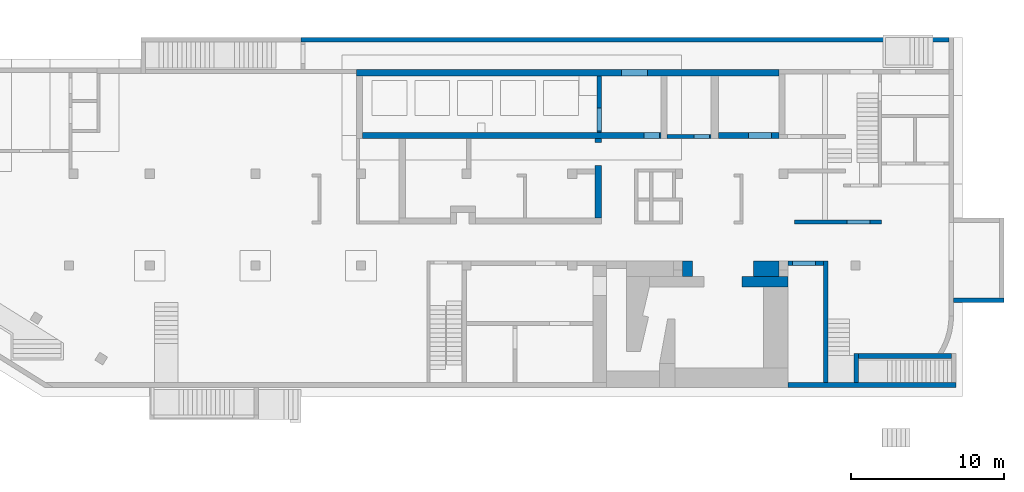
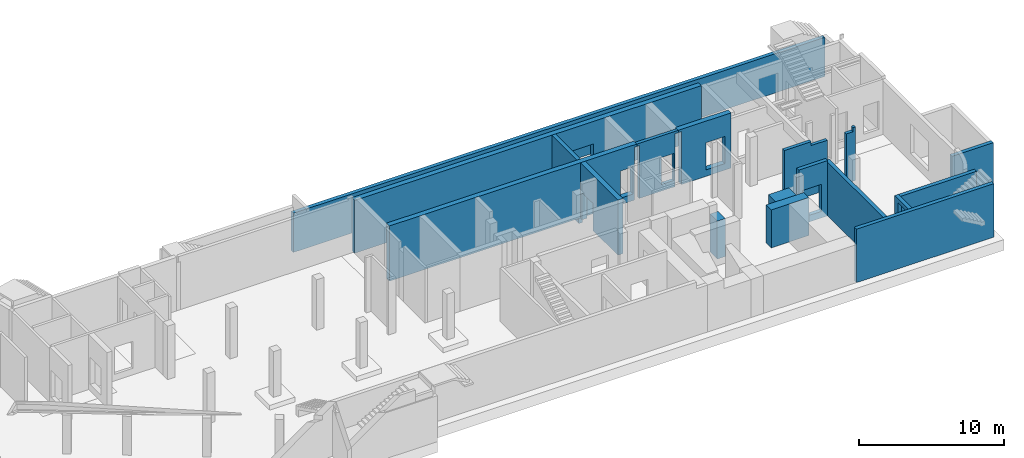
# One storey, part 7 of 9: 17 walls, 8 openings.
"""IFC4 building model written with IfcOpenShell, lengths in millimetres."""

from ifc_helpers import new_model, entity, si_unit, converted_unit, derived_unit, direction, frame, origin, place, context, subcontext, project, spatial, indexed_curve, outline, extrude, triangles, polygons, material, type_object, element, save


model = new_model("IFC4")

# Units and contexts
model_context = context("Model", 3, precision=0.01, world=origin(), true_north=direction((6.12303176911189e-17, 1.0)))
plan_context = context("Plan", 3, precision=0.01, world=origin(), true_north=direction((6.12303176911189e-17, 1.0)))
body_context = subcontext(model_context, "Body", "Model", "MODEL_VIEW")
ifc_project = project(units=[si_unit("LENGTHUNIT", "METRE", prefix="MILLI"), si_unit("AREAUNIT", "SQUARE_METRE"), si_unit("VOLUMEUNIT", "CUBIC_METRE"), converted_unit("PLANEANGLEUNIT", "DEGREE", entity("IfcRatioMeasure", 0.0174532925199433), si_unit("PLANEANGLEUNIT", "RADIAN"), dimensions=[0, 0, 0, 0, 0, 0, 0]), si_unit("MASSUNIT", "GRAM", prefix="KILO"), derived_unit("MASSDENSITYUNIT", [(si_unit("MASSUNIT", "GRAM", prefix="KILO"), 1), (si_unit("LENGTHUNIT", "METRE"), -3)]), derived_unit("MOMENTOFINERTIAUNIT", [(si_unit("LENGTHUNIT", "METRE"), 4)]), si_unit("TIMEUNIT", "SECOND"), si_unit("FREQUENCYUNIT", "HERTZ"), si_unit("THERMODYNAMICTEMPERATUREUNIT", "DEGREE_CELSIUS"), derived_unit("THERMALTRANSMITTANCEUNIT", [(si_unit("MASSUNIT", "GRAM", prefix="KILO"), 1), (si_unit("THERMODYNAMICTEMPERATUREUNIT", "KELVIN"), -1), (si_unit("TIMEUNIT", "SECOND"), -3)]), derived_unit("VOLUMETRICFLOWRATEUNIT", [(si_unit("LENGTHUNIT", "METRE"), 3), (si_unit("TIMEUNIT", "SECOND"), -1)]), derived_unit("MASSFLOWRATEUNIT", [(si_unit("MASSUNIT", "GRAM", prefix="KILO"), 1), (si_unit("TIMEUNIT", "SECOND"), -1)]), derived_unit("ROTATIONALFREQUENCYUNIT", [(si_unit("TIMEUNIT", "SECOND"), -1)]), si_unit("ELECTRICCURRENTUNIT", "AMPERE"), si_unit("ELECTRICVOLTAGEUNIT", "VOLT"), si_unit("POWERUNIT", "WATT"), si_unit("FORCEUNIT", "NEWTON", prefix="KILO"), si_unit("ILLUMINANCEUNIT", "LUX"), si_unit("LUMINOUSFLUXUNIT", "LUMEN"), si_unit("LUMINOUSINTENSITYUNIT", "CANDELA"), derived_unit("USERDEFINED", [(si_unit("MASSUNIT", "GRAM", prefix="KILO"), -1), (si_unit("LENGTHUNIT", "METRE"), -2), (si_unit("TIMEUNIT", "SECOND"), 3), (si_unit("LUMINOUSFLUXUNIT", "LUMEN"), 1)]), derived_unit("LINEARVELOCITYUNIT", [(si_unit("LENGTHUNIT", "METRE"), 1), (si_unit("TIMEUNIT", "SECOND"), -1)]), si_unit("PRESSUREUNIT", "PASCAL"), derived_unit("USERDEFINED", [(si_unit("LENGTHUNIT", "METRE"), -2), (si_unit("MASSUNIT", "GRAM", prefix="KILO"), 1), (si_unit("TIMEUNIT", "SECOND"), -2)]), derived_unit("LINEARFORCEUNIT", [(si_unit("MASSUNIT", "GRAM", prefix="KILO"), 1), (si_unit("LENGTHUNIT", "METRE"), 1), (si_unit("TIMEUNIT", "SECOND"), -2), (si_unit("LENGTHUNIT", "METRE"), -1)]), derived_unit("PLANARFORCEUNIT", [(si_unit("MASSUNIT", "GRAM", prefix="KILO"), 1), (si_unit("LENGTHUNIT", "METRE"), 1), (si_unit("TIMEUNIT", "SECOND"), -2), (si_unit("LENGTHUNIT", "METRE"), -2)])], contexts=[model_context, plan_context])

# Site, building, storey
site_placement = place(None, origin())
site = spatial("IfcSite", under=ifc_project, at=site_placement, CompositionType="ELEMENT")
building_placement = place(site_placement, origin())
building = spatial("IfcBuilding", under=site, at=building_placement, CompositionType="ELEMENT")
storey_placement = place(building_placement, frame((0.0, 0.0, -4900.0)))
storey = spatial("IfcBuildingStorey", under=building, at=storey_placement, CompositionType="ELEMENT", Elevation=-4900.0)

# Walls
ifc_material = material()
wall_type_1 = type_object("IfcWallType", PredefinedType="STANDARD")
wall_1_placement = place(storey_placement, frame((62870.0002685546, -100.000773643981, 0.0)))
element("IfcWall", 1, at=wall_1_placement, inside=storey, type_object=wall_type_1, material=ifc_material, PredefinedType="NOTDEFINED", context=body_context, shape_type="Tessellation", body=[
    polygons([(1.69593855051474e-12, -150.0, 0.0), (10955.0, -150.0, 0.0), (10955.0, -150.0, 4500.0), (4600.0, -150.0, 4500.0), (1.69593855051474e-12, -150.0, 4500.0), (1.69593855051474e-12, -150.0, 3200.0), (-3.39181412269712e-13, 150.0, 0.0), (-3.39181412269712e-13, 150.0, 4500.0), (2300.0, 150.0, 4500.0), (2600.0, 150.0, 4500.0), (4299.99999999999, 150.0, 4500.0), (4600.00000000002, 150.000000000001, 4500.0), (10955.0, 150.0, 4500.0), (10955.0, 150.0, 4229.99999999996), (10955.0, 150.0, 0.0), (10655.0, 150.0, 0.0), (4599.99999999999, 150.0, 0.0), (4299.99999999999, 150.0, 0.0), (2600.0, 150.0, 0.0), (2300.0, 150.0, 0.0)], [[[1, 2, 3, 4, 5, 6]], [[7, 8, 9, 10, 11, 12, 13, 14, 15, 16, 17, 18, 19, 20]], [[2, 1, 7, 20, 19, 18, 17, 16, 15]], [[1, 6, 5, 8, 7]], [[3, 2, 15, 14, 13]], [[4, 3, 13, 12]], [[5, 4, 12, 11, 10, 9, 8]]], closed=True),
])
wall_2_placement = place(storey_placement, frame((65320.0002685546, 49.9992263560015, 0.0), z_axis=(0.0, 0.0, 1.0), x_axis=(0.0, 1.0, 0.0)))
element("IfcWall", 2, at=wall_2_placement, inside=storey, type_object=wall_type_1, material=ifc_material, PredefinedType="NOTDEFINED", context=body_context, shape_type="Tessellation", body=[
    polygons([(1.01518793371724e-13, -150.000000000001, 0.0), (7950.00000000001, -150.000000000001, 0.0), (7950.00000000001, -150.000000000001, 4500.0), (3.38395977905748e-14, -150.000000000001, 4500.0), (2.16573425859679e-12, 150.000000000001, 0.0), (2.14035456025385e-12, 150.000000000001, 4500.0), (7950.00000000001, 150.000000000001, 4500.0), (7950.00000000001, 150.000000000001, 0.0), (7650.00000000001, 150.000000000001, 0.0)], [[[1, 2, 3, 4]], [[5, 6, 7, 8, 9]], [[2, 1, 5, 9, 8]], [[3, 2, 8, 7]], [[1, 4, 6, 5]], [[4, 3, 7, 6]]], closed=True),
])

# Wall, opening
wall_3_placement = place(storey_placement, frame((62870.0002685546, 7849.99922635602, 0.0)))
wall_3 = element("IfcWall", 3, at=wall_3_placement, inside=storey, type_object=wall_type_1, material=ifc_material, PredefinedType="NOTDEFINED", context=body_context, shape_type="Tessellation", body=[
    polygons([(2.00999830337293e-12, -149.999999999999, 0.0), (2299.99999999999, -149.999999999998, 0.0), (2299.99999999999, -149.999999999998, 4650.0), (2.00999830337293e-12, -149.999999999999, 4650.0), (299.999999999986, -149.999999999997, 2829.99999999805), (1799.99999999999, -149.999999999998, 2829.99999999804), (1799.99999999999, -149.999999999998, 550.0), (299.999999999986, -149.999999999997, 550.0), (2299.99999999999, 150.000000000002, 0.0), (4.00724627324388e-13, 150.000000000002, 0.0), (4.00724627324396e-13, 150.000000000001, 3200.0), (4.00724627324388e-13, 150.000000000002, 4650.0), (2299.99999999999, 150.000000000002, 4650.0), (2299.99999999999, 150.000000000002, 4500.0), (1799.99999999999, 150.000000000001, 2829.99999999804), (299.999999999993, 150.000000000002, 2829.99999999805), (299.999999999984, 150.000000000002, 550.0), (1799.99999999999, 150.000000000001, 550.0)], [[[1, 2, 3, 4], [5, 6, 7, 8]], [[9, 10, 11, 12, 13, 14], [15, 16, 17, 18]], [[2, 1, 10, 9]], [[4, 3, 13, 12]], [[1, 4, 12, 11, 10]], [[3, 2, 9, 14, 13]], [[5, 16, 15, 6]], [[6, 15, 18, 7]], [[7, 18, 17, 8]], [[16, 5, 8, 17]]], closed=True),
])
opening_1_placement = place(wall_3_placement, frame((-62870.0002685546, -7849.99922635602, 0.0)))
element("IfcOpeningElement", 4, at=opening_1_placement, cuts=wall_3, PredefinedType="OPENING", context=body_context, shape_type="SweptSolid", body=[
    extrude(outline(indexed_curve([(-750.000000000003, -1139.99999999902), (749.999999999994, -1139.99999999902), (749.999999999994, 1139.99999999902), (-750.000000000003, 1139.99999999902), (-750.000000000003, -1139.99999999902)], self_intersect=False)), frame((63920.0002685546, 7599.99922635407, 1690.0), z_axis=(0.0, 1.0, 0.0), x_axis=(1.0, 0.0, 0.0)), (0.0, 0.0, 1.0), 500.000000001943),
])

# Wall
wall_4_placement = place(storey_placement, frame((73525.0002685546, 1794.99922635597, 0.0), z_axis=(0.0, 0.0, 1.0), x_axis=(-1.0, 0.0, 0.0)))
element("IfcWall", 5, at=wall_4_placement, inside=storey, type_object=wall_type_1, material=ifc_material, PredefinedType="NOTDEFINED", context=body_context, shape_type="Tessellation", body=[
    triangles([(547.133825683544, -149.999930977401, 4499.99999694824), (-0.000219726614886895, -149.999930977401, 4229.99998035431), (903.567883300726, -149.999930977401, 0.000253295897891803), (-0.000219726614886895, -149.999930977401, 4499.99999694824), (-0.000219726614886895, -149.999930977401, 0.000253295897891803), (547.138476562439, -149.999930977401, 0.000253295897891803), (6055.00228271479, -149.999930977401, 4499.99999694824), (6055.00228271479, -149.999930977401, 0.000253295897891803), (6055.00228271479, 150.000071311417, 4499.99999694824), (6055.00228271479, 150.000071311417, 0.000253295897891803), (747.116967773385, 150.000071311417, 4499.99999694824), (-0.000219726614886895, 150.000071311417, 0.000253295897891803), (-0.000219726614886895, 150.000071311417, 4499.99999694824), (644.248828124939, 1.91826703590436, 4499.99999694824)], [[1, 2, 3], [1, 4, 2], [2, 5, 6], [7, 1, 3], [7, 3, 8], [3, 2, 6], [9, 10, 11], [11, 12, 13], [12, 11, 10], [6, 5, 12], [3, 12, 10], [12, 3, 6], [3, 10, 8], [13, 12, 2], [5, 2, 12], [4, 13, 2], [8, 10, 9], [9, 7, 8], [4, 1, 13], [14, 11, 13], [14, 13, 1], [7, 11, 14], [1, 7, 14], [9, 11, 7]]),
])

# Wall, opening
wall_5_placement = place(storey_placement, frame((67320.0002685546, 1944.99922635597, 0.0), z_axis=(0.0, 0.0, 1.0), x_axis=(0.0, -1.0, 0.0)))
wall_5 = element("IfcWall", 6, at=wall_5_placement, inside=storey, type_object=wall_type_1, material=ifc_material, PredefinedType="NOTDEFINED", context=body_context, shape_type="Tessellation", body=[
    polygons([(0.0, -150.000000000001, 0.0), (1894.99999999998, -150.000000000001, 0.0), (1894.99999999998, -150.000000000001, 4500.0), (0.0, -150.000000000001, 4500.0), (472.499999999996, -150.000000000001, 4179.99999999804), (1722.5, -150.000000000001, 4179.99999999804), (1722.5, -150.000000000001, 1825.0), (472.499999999996, -150.000000000001, 1825.0), (1894.99999999998, 150.000000000001, 0.0), (300.0, 150.000000000001, 0.0), (0.0, 150.000000000001, 0.0), (0.0, 150.000000000001, 4500.0), (299.999999999991, 150.000000000001, 4500.0), (1894.99999999998, 150.000000000001, 4500.0), (1722.5, 150.000000000001, 4179.99999999804), (472.499999999996, 150.000000000001, 4179.99999999804), (472.499999999996, 150.000000000001, 1825.0), (1722.5, 150.000000000001, 1825.0)], [[[1, 2, 3, 4], [5, 6, 7, 8]], [[9, 10, 11, 12, 13, 14], [15, 16, 17, 18]], [[2, 1, 11, 10, 9]], [[3, 2, 9, 14]], [[1, 4, 12, 11]], [[12, 4, 3, 14, 13]], [[5, 16, 15, 6]], [[6, 15, 18, 7]], [[7, 18, 17, 8]], [[16, 5, 8, 17]]], closed=True),
])
opening_2_placement = place(wall_5_placement, frame((1944.99922635597, -67320.0002685546, 0.0), z_axis=(0.0, 0.0, 1.0), x_axis=(0.0, 1.0, 0.0)))
element("IfcOpeningElement", 7, at=opening_2_placement, cuts=wall_5, PredefinedType="OPENING", context=body_context, shape_type="SweptSolid", body=[
    extrude(outline(indexed_curve([(-625.0, -1177.49999999902), (625.0, -1177.49999999902), (625.0, 1177.49999999902), (-625.0, 1177.49999999902), (-625.0, -1177.49999999902)], self_intersect=False)), frame((67070.0002685527, 847.499226355978, 3002.49999999902), z_axis=(1.0, 0.0, 0.0), x_axis=(0.0, -1.0, 0.0)), (0.0, 0.0, 1.0), 500.000000001948),
])

# Walls
wall_6_placement = place(storey_placement, frame((73670.0002685546, 5424.99922635595, 0.0)))
element("IfcWall", 8, at=wall_6_placement, inside=storey, type_object=wall_type_1, material=ifc_material, PredefinedType="NOTDEFINED", context=body_context, shape_type="Tessellation", body=[
    polygons([(4.01064381973369e-13, -149.999999999999, 0.0), (600.000000000003, -149.999999999999, 0.0), (3300.0, -149.999999999999, 0.0), (3300.0, -149.999999999999, 3500.0), (4.01064381973369e-13, -149.999999999999, 3500.0), (8.10145285698416e-12, 150.000000000001, 0.0), (8.10145285698416e-12, 150.000000000001, 3500.0), (3000.0, 150.000000000001, 3500.0), (3300.00000000002, 150.000000000001, 3500.0), (3299.99999999999, 150.000000000001, 0.0), (3000.0, 150.000000000001, 0.0)], [[[1, 2, 3, 4, 5]], [[6, 7, 8, 9, 10, 11]], [[3, 2, 1, 6, 11, 10]], [[4, 3, 10, 9]], [[1, 5, 7, 6]], [[5, 4, 9, 8, 7]]], closed=True),
])
wall_7_placement = place(storey_placement, frame((73370.0002685547, 22449.9992263559, 0.0), z_axis=(0.0, 0.0, 1.0), x_axis=(-1.0, 0.0, 0.0)))
element("IfcWall", 9, at=wall_7_placement, inside=storey, type_object=wall_type_1, material=ifc_material, PredefinedType="NOTDEFINED", context=body_context, shape_type="Tessellation", body=[
    polygons([(5.41415833087696e-13, -150.000000000001, 0.0), (42310.0, -149.999999999996, 0.0), (42310.0, -149.999999999996, 3300.0), (5.41415833087696e-13, -150.000000000001, 3300.0), (-2.70734306312946e-13, 150.000000000001, 0.0), (-2.70734306312946e-13, 150.000000000001, 3300.0), (42060.0, 150.000000000001, 3300.0), (42310.0, 150.000000000005, 3300.0), (42310.0, 150.000000000005, 0.0), (42060.0, 150.000000000001, 0.0)], [[[1, 2, 3, 4]], [[5, 6, 7, 8, 9, 10]], [[2, 1, 5, 10, 9]], [[1, 4, 6, 5]], [[4, 3, 8, 7, 6]], [[3, 2, 9, 8]]], closed=True),
])

# Wall, opening
wall_8_placement = place(storey_placement, frame((50520.0002685547, 20099.9992263561, -750.0), z_axis=(0.0, 0.0, 1.0), x_axis=(0.0, -1.0, 0.0)))
wall_8 = element("IfcWall", 10, at=wall_8_placement, inside=storey, type_object=wall_type_1, material=ifc_material, PredefinedType="NOTDEFINED", context=body_context, shape_type="Tessellation", body=[
    polygons([(3700.00000000001, -149.999999999999, 5200.0), (0.0, -150.0, 5200.0), (0.0, -150.0, 749.999999999998), (0.0, -150.0, 0.0), (1299.99999999996, -149.999999999997, 0.0), (3700.00000000001, -149.999999999999, 0.0), (3700.00000000001, -149.999999999999, 749.999999999998), (2100.00000000001, -150.000000000004, 2379.99999999804), (3600.00000000001, -150.0, 2379.99999999804), (3600.00000000001, -150.0, 249.999999999999), (2100.00000000001, -150.000000000004, 249.999999999999), (3700.00000000001, 150.000000000002, 0.0), (0.0, 150.000000000001, 0.0), (0.0, 150.000000000001, 749.999999999998), (0.0, 150.000000000001, 5200.0), (3700.00000000001, 150.000000000002, 5200.0), (3700.00000000001, 150.000000000002, 749.999999999998), (3600.00000000001, 150.000000000001, 2379.99999999804), (2100.00000000001, 150.000000000006, 2379.99999999804), (2100.00000000001, 150.000000000006, 249.999999999999), (3600.00000000001, 150.000000000001, 249.999999999999)], [[[1, 2, 3, 4, 5, 6, 7], [8, 9, 10, 11]], [[12, 13, 14, 15, 16, 17], [18, 19, 20, 21]], [[13, 12, 6, 5, 4]], [[2, 1, 16, 15]], [[2, 15, 14, 13, 4, 3]], [[6, 12, 17, 16, 1, 7]], [[18, 9, 8, 19]], [[11, 20, 19, 8]], [[20, 11, 10, 21]], [[21, 10, 9, 18]]], closed=True),
])
opening_3_placement = place(wall_8_placement, frame((20099.9992263561, -50520.0002685547, 750.0), z_axis=(0.0, 0.0, 1.0), x_axis=(0.0, 1.0, 0.0)))
element("IfcOpeningElement", 11, at=opening_3_placement, cuts=wall_8, PredefinedType="OPENING", context=body_context, shape_type="SweptSolid", body=[
    extrude(outline(indexed_curve([(-1064.99999999902, -749.999999999998), (1064.99999999902, -749.999999999998), (1064.99999999902, 750.000000000001), (-1064.99999999902, 750.000000000001), (-1064.99999999902, -749.999999999998)], self_intersect=False)), frame((50270.0002685547, 17249.9992263561, 565.0), z_axis=(1.0, 0.0, 0.0), x_axis=(0.0, 0.0, -1.0)), (0.0, 0.0, 1.0), 500.000000001948),
])

# Walls
wall_type_2 = type_object("IfcWallType", PredefinedType="STANDARD")
wall_9_placement = place(storey_placement, frame((59870.0002685546, 6649.99922635604, 0.0)))
element("IfcWall", 12, at=wall_9_placement, inside=storey, type_object=wall_type_2, material=ifc_material, PredefinedType="NOTDEFINED", context=body_context, shape_type="Tessellation", body=[
    polygons([(4.28224994962343e-12, -349.999999999999, 0.0), (1400.00000000002, -349.999999999999, 0.0), (3000.00000000002, -349.999999999999, 0.0), (3000.00000000002, -349.999999999999, 3200.0), (1400.00000000002, -349.999999999999, 3200.0), (4.28224994962343e-12, -349.999999999999, 3200.0), (1.87040952527702e-12, 350.000000000002, 0.0), (1.87040952527702e-12, 350.000000000002, 3200.0), (750.000000000005, 350.000000000001, 3200.0), (2400.00000000002, 350.000000000001, 3200.0), (3000.00000000004, 350.000000000001, 3200.0), (3000.00000000001, 350.000000000001, 0.0), (2400.00000000002, 350.000000000001, 0.0), (750.000000000005, 350.000000000001, 0.0)], [[[1, 2, 3, 4, 5, 6]], [[7, 8, 9, 10, 11, 12, 13, 14]], [[3, 2, 1, 7, 14, 13, 12]], [[1, 6, 8, 7]], [[4, 3, 12, 11]], [[6, 5, 4, 11, 10, 9, 8]]], closed=True),
])
wall_type_3 = type_object("IfcWallType", PredefinedType="STANDARD")
wall_10_placement = place(storey_placement, frame((63285.0002685546, 10550.0, 0.0)))
element("IfcWall", 13, at=wall_10_placement, inside=storey, type_object=wall_type_3, material=ifc_material, PredefinedType="NOTDEFINED", context=body_context, shape_type="Tessellation", body=[
    polygons([(7.89039547462626e-12, -125.0, 0.0), (5685.0, -125.0, 0.0), (5685.0, -125.0, 4500.0), (5484.99999999999, -125.0, 4500.0), (5484.99999999999, -125.000257881502, 4170.0), (4945.00000000001, -125.0, 4169.99999999935), (4945.00000000001, -125.0, 550.0), (3445.0, -125.0, 550.0), (3445.0, -125.0, 4169.99999999935), (2145.00000000002, -125.000257881506, 4170.0), (2145.00000000002, -125.0, 4500.0), (7.89039547462626e-12, -125.0, 4500.0), (5685.0, 125.0, 0.0), (7.04089212457092e-12, 125.0, 0.0), (7.04089212457092e-12, 125.0, 4500.0), (1844.99999999999, 125.0, 4500.0), (2145.00000000002, 125.000000000002, 4500.0), (2145.00000000002, 125.0, 4170.0), (3445.0, 125.0, 4169.99999999935), (3445.0, 125.0, 550.0), (4945.00000000002, 125.0, 550.0), (4945.00000000001, 125.0, 4169.99999999935), (5484.99999999999, 125.0, 4170.0), (5484.99999999999, 125.0, 4500.0), (5685.0, 125.0, 4500.0)], [[[1, 2, 3, 4, 5, 6, 7, 8, 9, 10, 11, 12]], [[13, 14, 15, 16, 17, 18, 19, 20, 21, 22, 23, 24, 25]], [[2, 1, 14, 13]], [[3, 2, 13, 25]], [[3, 25, 24, 4]], [[1, 12, 15, 14]], [[5, 23, 22, 6]], [[10, 18, 17, 11]], [[23, 5, 4, 24]], [[8, 20, 19, 9]], [[20, 8, 7, 21]], [[21, 7, 6, 22]], [[18, 10, 9, 19]], [[15, 12, 11, 17, 16]]], closed=True),
])

# Wall, opening
wall_11_placement = place(storey_placement, frame((58070.0002685547, 16124.999226356, 0.0), z_axis=(0.0, 0.0, 1.0), x_axis=(-1.0, 0.0, 0.0)))
wall_11 = element("IfcWall", 14, at=wall_11_placement, inside=storey, type_object=wall_type_3, material=ifc_material, PredefinedType="NOTDEFINED", context=body_context, shape_type="Tessellation", body=[
    polygons([(249.999999999995, -125.000000000002, 0.0), (3100.00000000002, -124.999999999995, 0.0), (3100.00000000002, -125.0, 4450.0), (3300.00000000001, -124.999999999995, 4450.0), (3300.00000000001, -124.999999999995, 4650.0), (1.70289415178989e-13, -125.000000000002, 4650.0), (1.70289415178989e-13, -125.000000000002, 4450.0), (249.999999999995, -125.000000000002, 4450.0), (349.999999999999, -125.000000000002, 2829.99999999805), (1349.99999999999, -125.0, 2829.99999999804), (1349.99999999999, -125.0, 550.0), (349.999999999999, -125.000000000002, 550.0), (3100.00000000002, 125.000000000002, 0.0), (249.999999999995, 125.0, 0.0), (249.999999999995, 125.0, 4450.0), (-6.31986186424167e-13, 125.0, 4450.0), (-6.31986186424167e-13, 125.0, 4650.0), (3300.00000000001, 125.000000000002, 4650.0), (3300.00000000001, 125.000000000002, 4450.0), (3100.00000000002, 125.000000000002, 4450.0), (1349.99999999999, 124.999999999998, 2829.99999999804), (349.999999999998, 125.0, 2829.99999999805), (349.999999999998, 125.0, 550.0), (1349.99999999999, 124.999999999998, 550.0)], [[[1, 2, 3, 4, 5, 6, 7, 8], [9, 10, 11, 12]], [[13, 14, 15, 16, 17, 18, 19, 20], [21, 22, 23, 24]], [[2, 1, 14, 13]], [[6, 5, 18, 17]], [[9, 22, 21, 10]], [[10, 21, 24, 11]], [[11, 24, 23, 12]], [[22, 9, 12, 23]], [[18, 5, 4, 19]], [[19, 4, 3, 20]], [[2, 13, 20, 3]], [[6, 17, 16, 7]], [[7, 16, 15, 8]], [[14, 1, 8, 15]]], closed=True),
])
opening_4_placement = place(wall_11_placement, frame((58070.0002685547, 16124.999226356, 0.0), z_axis=(0.0, 0.0, 1.0), x_axis=(-1.0, 0.0, 0.0)))
element("IfcOpeningElement", 15, at=opening_4_placement, cuts=wall_11, PredefinedType="OPENING", context=body_context, shape_type="SweptSolid", body=[
    extrude(outline(indexed_curve([(-499.999999999999, -1139.99999999902), (499.999999999999, -1139.99999999902), (499.999999999999, 1139.99999999902), (-499.999999999999, 1139.99999999902), (-499.999999999999, -1139.99999999902)], self_intersect=False)), frame((57220.0002685547, 16349.999226357, 1690.0), z_axis=(0.0, -1.0, 0.0), x_axis=(-1.0, 0.0, 0.0)), (0.0, 0.0, 1.0), 450.000000000965),
])

# Walls
wall_type_4 = type_object("IfcWallType", PredefinedType="STANDARD")
wall_12_placement = place(storey_placement, frame((55970.0002685547, 7499.99922635604, 0.0)))
element("IfcWall", 16, at=wall_12_placement, inside=storey, type_object=wall_type_4, material=ifc_material, PredefinedType="NOTDEFINED", context=body_context, shape_type="Tessellation", body=[
    polygons([(2.66552166520652e-12, -500.0, 0.0), (649.999999999985, -500.0, 0.0), (649.999999999985, -500.0, 3200.0), (2.66552166520652e-12, -500.0, 3200.0), (649.999999999981, 500.0, 0.0), (-6.66377194173235e-13, 500.0, 0.0), (-6.66377194173235e-13, 500.0, 3200.0), (649.999999999981, 500.0, 3200.0), (1.33276212145463e-12, -100.000000000002, 0.0), (1.33276212145461e-12, -99.9999999999978, 3200.0)], [[[1, 2, 3, 4]], [[5, 6, 7, 8]], [[2, 1, 9, 6, 5]], [[2, 5, 8, 3]], [[6, 9, 1, 4, 10, 7]], [[4, 3, 8, 7, 10]]], closed=True),
])
wall_13_placement = place(storey_placement, frame((60620.0002685546, 7499.99922635603, 0.0)))
element("IfcWall", 17, at=wall_13_placement, inside=storey, type_object=wall_type_4, material=ifc_material, PredefinedType="NOTDEFINED", context=body_context, shape_type="Tessellation", body=[
    polygons([(-1.57507641442058e-12, -500.0, 0.0), (1650.00000000001, -500.000000000001, 0.0), (1650.00000000001, -500.000000000001, 3200.0), (-1.57507641442058e-12, -500.0, 3200.0), (1650.00000000001, 500.0, 0.0), (-5.51277506641469e-12, 499.999999999999, 0.0), (-5.51277506641469e-12, 499.999999999999, 3200.0), (1650.00000000001, 500.0, 3200.0), (1650.00000000001, -99.9999999999989, 0.0), (1650.00000000001, -99.9999999999989, 3200.0)], [[[1, 2, 3, 4]], [[5, 6, 7, 8]], [[2, 1, 6, 5, 9]], [[2, 9, 5, 8, 10, 3]], [[6, 1, 4, 7]], [[4, 3, 10, 8, 7]]], closed=True),
])

# Wall, opening
wall_type_5 = type_object("IfcWallType", PredefinedType="STANDARD")
wall_14_placement = place(storey_placement, frame((62270.0002685547, 20299.999226356, 0.0), z_axis=(0.0, 0.0, 1.0), x_axis=(-1.0, 0.0, 0.0)))
wall_14 = element("IfcWall", 18, at=wall_14_placement, inside=storey, type_object=wall_type_5, material=ifc_material, PredefinedType="NOTDEFINED", context=body_context, shape_type="Tessellation", body=[
    polygons([(3.98557861925833e-13, -200.000000000002, 0.0), (27600.0, -200.000000000002, 0.0), (27600.0, -200.000000000002, 4450.0), (27200.0, -200.000000000002, 4450.0), (3.98557861925833e-13, -200.000000000002, 4450.0), (3.98557861925833e-13, -200.000000000002, 4170.0), (8600.00000000001, -200.000000000323, 2550.0), (10300.0, -200.000000000323, 2550.0), (10300.0, -200.000000000323, 850.00000000001), (8600.00000000001, -200.000000000323, 850.00000000001), (-9.61482270122758e-13, 199.999999999998, 0.0), (-9.61482270122758e-13, 199.999999999998, 4450.0), (3950.0, 199.999999999998, 4450.0), (4450.0, 200.000000000002, 4450.0), (7300.00000000002, 199.999999999998, 4450.0), (7700.00000000002, 199.999999999998, 4450.0), (11600.0, 199.999999999998, 4450.0), (11900.0, 199.999999999998, 4450.0), (27200.0, 199.999999999998, 4450.0), (27600.0, 199.999999999998, 4450.0), (27600.0, 199.999999999998, 0.0), (27200.0, 199.999999999998, 0.0), (7700.00000000002, 199.999999999998, 0.0), (7300.00000000002, 199.999999999998, 0.0), (4450.0, 200.000000000002, 0.0), (3950.0, 199.999999999998, 0.0), (10300.0, 199.999999999998, 2550.0), (8600.00000000001, 199.999999999998, 2550.0), (8600.00000000001, 199.999999999998, 850.00000000001), (10300.0, 199.999999999998, 850.00000000001), (-6.21472237110631e-13, 100.000000000003, 0.0), (27600.0, 50.0000000000016, 0.0)], [[[1, 2, 3, 4, 5, 6], [7, 8, 9, 10]], [[11, 12, 13, 14, 15, 16, 17, 18, 19, 20, 21, 22, 23, 24, 25, 26], [27, 28, 29, 30]], [[2, 1, 31, 11, 26, 25, 24, 23, 22, 21, 32]], [[5, 4, 3, 20, 19, 18, 17, 16, 15, 14, 13, 12]], [[1, 6, 5, 12, 11, 31]], [[3, 2, 32, 21, 20]], [[8, 7, 28, 27]], [[8, 27, 30, 9]], [[9, 30, 29, 10]], [[28, 7, 10, 29]]], closed=True),
])
opening_5_placement = place(wall_14_placement, frame((62270.0002685547, 20299.999226356, 0.0), z_axis=(0.0, 0.0, 1.0), x_axis=(-1.0, 0.0, 0.0)))
element("IfcOpeningElement", 19, at=opening_5_placement, cuts=wall_14, PredefinedType="OPENING", context=body_context, shape_type="SweptSolid", body=[
    extrude(outline(indexed_curve([(-849.999999999997, -849.999999999994), (850.000000000006, -849.999999999994), (850.000000000006, 849.999999999994), (-849.999999999997, 849.999999999994), (-849.999999999997, -849.999999999994)], self_intersect=False)), frame((52820.0002685547, 20499.999226357, 1700.0), z_axis=(0.0, -1.0, 0.0), x_axis=(-1.0, 0.0, 0.0)), (0.0, 0.0, 1.0), 400.000000000962),
])

wall_15_placement = place(storey_placement, frame((62270.0002685547, 16199.999226356, 0.0), z_axis=(0.0, 0.0, 1.0), x_axis=(-1.0, 0.0, 0.0)))
wall_15 = element("IfcWall", 20, at=wall_15_placement, inside=storey, type_object=wall_type_5, material=ifc_material, PredefinedType="NOTDEFINED", context=body_context, shape_type="Tessellation", body=[
    polygons([(-1.23756482706569e-12, -200.0, 0.0), (3949.99999999999, -200.0, 0.0), (3949.99999999999, -200.0, 4450.0), (4200.0, -200.0, 4450.0), (4200.0, -200.0, 4650.0), (-1.23756482706569e-12, -200.0, 4650.0), (499.999999999989, -200.0, 2829.99999999805), (1999.99999999999, -199.999999999998, 2829.99999999804), (1999.99999999999, -199.999999999998, 550.0), (499.999999999989, -200.0, 550.0), (3949.99999999999, 200.0, 0.0), (-2.47512726054956e-12, 200.0, 0.0), (-2.47512726054956e-12, 200.0, 4170.0), (-2.47512726054956e-12, 200.0, 4450.0), (-2.47512726054956e-12, 200.0, 4650.0), (4200.0, 200.0, 4650.0), (4200.0, 200.0, 4450.0), (3949.99999999999, 200.0, 4450.0), (1999.99999999999, 200.0, 2829.99999999804), (499.999999999988, 199.999999999998, 2829.99999999805), (499.999999999988, 199.999999999998, 550.0), (1999.99999999999, 200.0, 550.0), (-1.70165073962216e-12, -49.9999999999973, 0.0), (4200.0, -50.0000000000016, 4650.0), (4200.0, -50.0000000000016, 4450.0)], [[[1, 2, 3, 4, 5, 6], [7, 8, 9, 10]], [[11, 12, 13, 14, 15, 16, 17, 18], [19, 20, 21, 22]], [[2, 1, 23, 12, 11]], [[6, 5, 24, 16, 15]], [[1, 6, 15, 14, 13, 12, 23]], [[7, 20, 19, 8]], [[8, 19, 22, 9]], [[9, 22, 21, 10]], [[20, 7, 10, 21]], [[16, 24, 5, 4, 25, 17]], [[17, 25, 4, 3, 18]], [[2, 11, 18, 3]]], closed=True),
])
opening_6_placement = place(wall_15_placement, frame((62270.0002685547, 16199.999226356, 0.0), z_axis=(0.0, 0.0, 1.0), x_axis=(-1.0, 0.0, 0.0)))
element("IfcOpeningElement", 21, at=opening_6_placement, cuts=wall_15, PredefinedType="OPENING", context=body_context, shape_type="SweptSolid", body=[
    extrude(outline(indexed_curve([(-749.999999999994, -1139.99999999902), (750.000000000003, -1139.99999999902), (750.000000000003, 1139.99999999902), (-749.999999999994, 1139.99999999902), (-749.999999999994, -1139.99999999902)], self_intersect=False)), frame((61020.0002685547, 16499.999226358, 1690.0), z_axis=(0.0, -1.0, 0.0), x_axis=(-1.0, 0.0, 0.0)), (0.0, 0.0, 1.0), 600.000000001943),
])

wall_16_placement = place(storey_placement, frame((54770.0002685547, 16199.999226356, 0.0), z_axis=(0.0, 0.0, 1.0), x_axis=(-1.0, 0.0, 0.0)))
wall_16 = element("IfcWall", 22, at=wall_16_placement, inside=storey, type_object=wall_type_5, material=ifc_material, PredefinedType="NOTDEFINED", context=body_context, shape_type="Tessellation", body=[
    polygons([(199.999999999998, -200.0, 0.0), (19700.0, -200.0, 0.0), (19700.0, -200.0, 4650.0), (5.72325115210965e-13, -200.0, 4650.0), (5.72325115210965e-13, -200.0, 4450.0), (199.999999999998, -200.0, 4450.0), (299.999999999984, -200.0, 2829.99999999805), (1299.99999999999, -199.999999999998, 2829.99999999804), (1299.99999999999, -199.999999999998, 550.0), (299.999999999984, -200.0, 550.0), (19700.0, 199.999999999998, 0.0), (17305.0, 200.000000000002, 0.0), (16905.0, 200.0, 0.0), (12900.0, 200.0, 0.0), (12600.0, 200.000000000002, 0.0), (4499.99999999999, 200.000000000002, 0.0), (4099.99999999999, 200.0, 0.0), (199.999999999997, 200.0, 0.0), (199.999999999997, 200.0, 4450.0), (-7.09380977484016e-13, 200.0, 4450.0), (-7.09380977484016e-13, 200.0, 4650.0), (4099.99999999999, 200.0, 4650.0), (4499.99999999999, 200.000000000002, 4650.0), (12600.0, 200.000000000002, 4650.0), (12900.0, 200.0, 4650.0), (16905.0, 200.0, 4650.0), (17305.0, 200.000000000002, 4650.0), (19700.0, 199.999999999998, 4650.0), (1299.99999999999, 200.0, 2829.99999999804), (299.999999999983, 200.0, 2829.99999999805), (299.999999999983, 200.0, 550.0), (1299.99999999999, 200.0, 550.0), (9.16853304503353e-14, -49.9999999999973, 4650.0), (9.16853304503353e-14, -49.9999999999973, 4450.0)], [[[1, 2, 3, 4, 5, 6], [7, 8, 9, 10]], [[11, 12, 13, 14, 15, 16, 17, 18, 19, 20, 21, 22, 23, 24, 25, 26, 27, 28], [29, 30, 31, 32]], [[2, 1, 18, 17, 16, 15, 14, 13, 12, 11]], [[4, 3, 28, 27, 26, 25, 24, 23, 22, 21, 33]], [[3, 2, 11, 28]], [[7, 30, 29, 8]], [[8, 29, 32, 9]], [[9, 32, 31, 10]], [[30, 7, 10, 31]], [[4, 33, 21, 20, 34, 5]], [[5, 34, 20, 19, 6]], [[18, 1, 6, 19]]], closed=True),
])
opening_7_placement = place(wall_16_placement, frame((54770.0002685547, 16199.999226356, 0.0), z_axis=(0.0, 0.0, 1.0), x_axis=(-1.0, 0.0, 0.0)))
element("IfcOpeningElement", 23, at=opening_7_placement, cuts=wall_16, PredefinedType="OPENING", context=body_context, shape_type="SweptSolid", body=[
    extrude(outline(indexed_curve([(-500.000000000008, -1139.99999999902), (499.99999999999, -1139.99999999902), (499.99999999999, 1139.99999999902), (-500.000000000008, 1139.99999999902), (-500.000000000008, -1139.99999999902)], self_intersect=False)), frame((53970.0002685547, 16499.999226358, 1690.0), z_axis=(0.0, -1.0, 0.0), x_axis=(-1.0, 0.0, 0.0)), (0.0, 0.0, 1.0), 600.000000001943),
])

wall_17_placement = place(storey_placement, frame((50470.0002685547, 15999.9992263561, 0.0), z_axis=(0.0, 0.0, 1.0), x_axis=(0.0, -1.0, 0.0)))
wall_17 = element("IfcWall", 24, at=wall_17_placement, inside=storey, type_object=wall_type_5, material=ifc_material, PredefinedType="NOTDEFINED", context=body_context, shape_type="Tessellation", body=[
    polygons([(5174.99999999991, -199.999999999997, 4650.0), (2299.99999999981, -199.999999999993, 4650.0), (1999.99999999982, -199.999999999994, 4650.0), (0.0, -199.999999999997, 4650.0), (2.16573425859679e-12, -199.999999999997, 0.0), (249.999999999815, -199.999999999996, 0.0), (249.999999999813, -199.999999999996, 2279.99999999804), (1749.99999999981, -199.999999999994, 2279.99999999804), (1749.99999999981, -199.999999999994, 0.0), (1999.99999999981, -199.999999999994, 0.0), (2299.99999999981, -199.999999999993, 0.0), (5174.99999999991, -199.999999999997, 0.0), (2.16573425859679e-12, 199.999999999999, 4650.0), (5174.99999999991, 199.999999999998, 4650.0), (5174.99999999991, 199.999999999998, 0.0), (1749.99999999981, 200.000000000002, 0.0), (1749.99999999981, 200.000000000002, 2279.99999999804), (249.999999999813, 199.999999999999, 2279.99999999804), (249.999999999815, 199.999999999999, 0.0), (2.16573425859679e-12, 199.999999999999, 0.0)], [[[1, 2, 3, 4, 5, 6, 7, 8, 9, 10, 11, 12]], [[13, 14, 15, 16, 17, 18, 19, 20]], [[5, 20, 19, 6]], [[4, 3, 2, 1, 14, 13]], [[5, 4, 13, 20]], [[1, 12, 15, 14]], [[7, 18, 17, 8]], [[8, 17, 16, 9]], [[18, 7, 6, 19]], [[15, 12, 11, 10, 9, 16]]], closed=True),
])
opening_8_placement = place(wall_17_placement, frame((15999.9992263561, -50470.0002685547, 0.0), z_axis=(0.0, 0.0, 1.0), x_axis=(0.0, 1.0, 0.0)))
element("IfcOpeningElement", 25, at=opening_8_placement, cuts=wall_17, PredefinedType="OPENING", context=body_context, shape_type="SweptSolid", body=[
    extrude(outline(indexed_curve([(-750.000000000001, -1139.99999999902), (749.999999999998, -1139.99999999902), (749.999999999998, 1139.99999999902), (-750.000000000001, 1139.99999999902), (-750.000000000001, -1139.99999999902)], self_intersect=False)), frame((50170.0002685527, 14999.9992263562, 1140.0), z_axis=(1.0, 0.0, 0.0), x_axis=(0.0, -1.0, 0.0)), (0.0, 0.0, 1.0), 600.000000001943),
])

save(model, "model.ifc")
